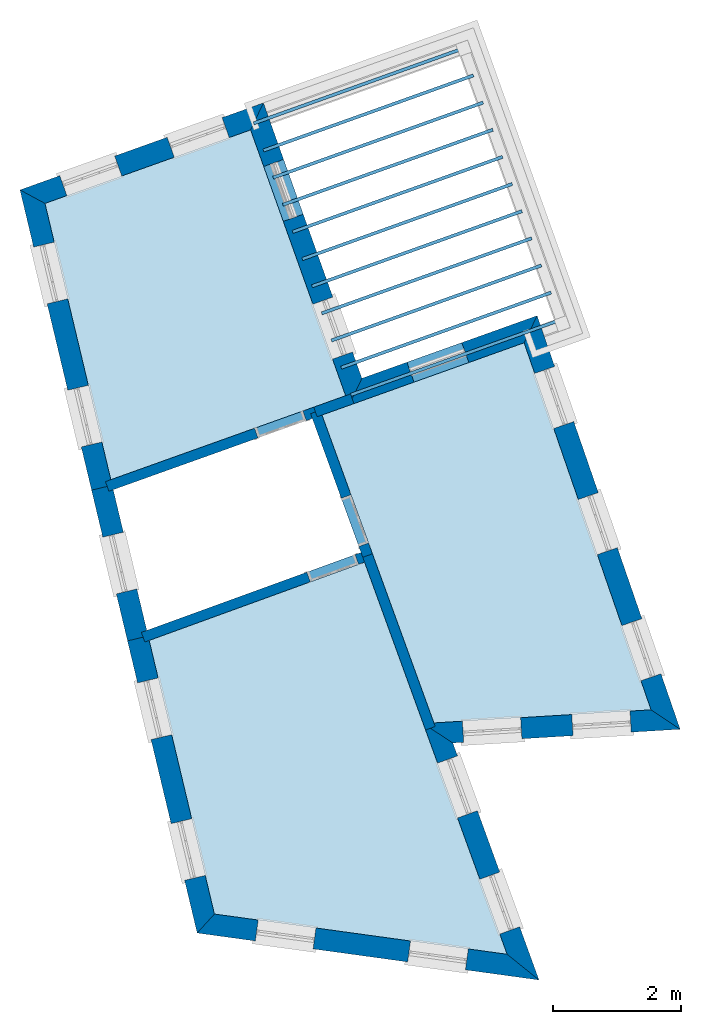
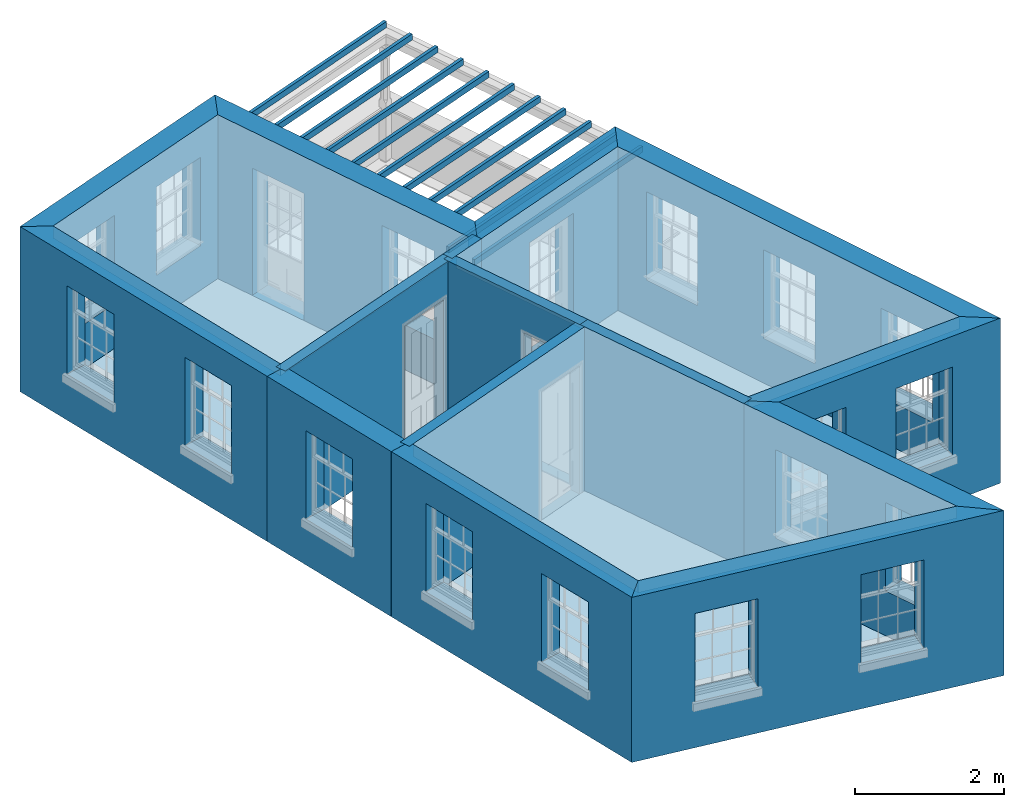
# One storey, part 1 of 12: 17 slabs, 15 walls, 22 openings.
"""IFC2X3 building model written with IfcOpenShell, lengths in metres."""

from ifc_helpers import new_model, si_unit, frame, origin, place, context, subcontext, project, spatial, polyline, outline, extrude, material, layer, layer_set, layer_usage, element, save


model = new_model("IFC2X3")

# Units and contexts
model_context = context("Model", 3, world=origin())
body_context = subcontext(model_context, "Body", "Model", "MODEL_VIEW")
ifc_project = project(units=[si_unit("PLANEANGLEUNIT", "RADIAN"), si_unit("MASSUNIT", "GRAM", prefix="KILO"), si_unit("FORCEUNIT", "NEWTON", prefix="KILO"), si_unit("LENGTHUNIT", "METRE")], contexts=[model_context])

# Site, building, storey
site_placement = place(None, origin())
site = spatial("IfcSite", under=ifc_project, at=site_placement, CompositionType="ELEMENT")
building_placement = place(None, origin())
building = spatial("IfcBuilding", under=site, at=building_placement, Name="Building plot-12", CompositionType="ELEMENT")
storey_placement = place(None, frame((0.0, 0.0, 6.45)))
storey = spatial("IfcBuildingStorey", under=building, at=storey_placement, Name="Floor 1", CompositionType="ELEMENT", Elevation=6.45)

# Slabs
slab_1_placement = place(storey_placement, frame((0.0, 0.0, 2.5)))
element("IfcSlab", 1, at=slab_1_placement, inside=storey, Name="Slab", ObjectType="Slab", PredefinedType="FLOOR", context=body_context, shape_type="SweptSolid", body=[
    extrude(outline(polyline([(56.3536968527592, 44.1243472572147), (53.1438565991735, 42.9766000900277), (54.1719070946365, 38.6653233374711), (57.8370699166001, 39.9758808462095), (56.3536968527592, 44.1243472572147)])), origin(), (0.0, 0.0, 1.0), 0.2),
])
slab_2_placement = place(storey_placement, frame((0.0, 0.0, 2.5)))
element("IfcSlab", 2, at=slab_2_placement, inside=storey, Name="Slab", ObjectType="Slab", PredefinedType="FLOOR", context=body_context, shape_type="SweptSolid", body=[
    extrude(outline(polyline([(57.4677288305129, 39.6738940222548), (59.2146610939911, 34.8688206458638), (62.6036094343713, 35.0733568984167), (60.6224114250311, 40.801918386454), (57.4677288305129, 39.6738940222548)])), origin(), (0.0, 0.0, 1.0), 0.2),
])
slab_3_placement = place(storey_placement, frame((0.0, 0.0, 2.5)))
element("IfcSlab", 3, at=slab_3_placement, inside=storey, Name="Slab", ObjectType="Slab", PredefinedType="FLOOR", context=body_context, shape_type="SweptSolid", body=[
    extrude(outline(polyline([(54.7702024726653, 36.1562861200959), (55.7885191142734, 31.8858296755126), (60.357257872223, 31.2577442307242), (58.1319962759778, 37.3784997260365), (54.7702024726653, 36.1562861200959)])), origin(), (0.0, 0.0, 1.0), 0.2),
])
slab_4_placement = place(storey_placement, frame((0.0, 0.0, 2.2)))
element("IfcSlab", 4, at=slab_4_placement, inside=storey, Name="Slab", ObjectType="Slab", PredefinedType="FLOOR", context=body_context, shape_type="SweptSolid", body=[
    extrude(outline(polyline([(56.3936730760147, 44.2501522713207), (56.4105077896063, 44.2030715701971), (59.6885342848072, 45.3752001892546), (59.6716995712156, 45.4222808903782), (56.3936730760147, 44.2501522713207)])), origin(), (0.0, 0.0, 1.0), 0.1),
])
slab_5_placement = place(storey_placement, frame((0.0, 0.0, 2.2)))
element("IfcSlab", 5, at=slab_5_placement, inside=storey, Name="Slab", ObjectType="Slab", PredefinedType="FLOOR", context=body_context, shape_type="SweptSolid", body=[
    extrude(outline(polyline([(56.5451854983388, 43.8264259612083), (56.5620202119304, 43.7793452600847), (59.8400467071313, 44.9514738791422), (59.8232119935397, 44.9985545802658), (56.5451854983388, 43.8264259612083)])), origin(), (0.0, 0.0, 1.0), 0.1),
])
slab_6_placement = place(storey_placement, frame((0.0, 0.0, 2.2)))
element("IfcSlab", 6, at=slab_6_placement, inside=storey, Name="Slab", ObjectType="Slab", PredefinedType="FLOOR", context=body_context, shape_type="SweptSolid", body=[
    extrude(outline(polyline([(56.6966979206629, 43.4026996510959), (56.7135326342544, 43.3556189499722), (59.9915591294554, 44.5277475690297), (59.9747244158638, 44.5748282701533), (56.6966979206629, 43.4026996510959)])), origin(), (0.0, 0.0, 1.0), 0.1),
])
slab_7_placement = place(storey_placement, frame((0.0, 0.0, 2.2)))
element("IfcSlab", 7, at=slab_7_placement, inside=storey, Name="Slab", ObjectType="Slab", PredefinedType="FLOOR", context=body_context, shape_type="SweptSolid", body=[
    extrude(outline(polyline([(56.848210342987, 42.9789733409834), (56.8650450565785, 42.9318926398598), (60.1430715517794, 44.1040212589173), (60.1262368381879, 44.1511019600409), (56.848210342987, 42.9789733409834)])), origin(), (0.0, 0.0, 1.0), 0.1),
])
slab_8_placement = place(storey_placement, frame((0.0, 0.0, 2.2)))
element("IfcSlab", 8, at=slab_8_placement, inside=storey, Name="Slab", ObjectType="Slab", PredefinedType="FLOOR", context=body_context, shape_type="SweptSolid", body=[
    extrude(outline(polyline([(56.999722765311, 42.555247030871), (57.0165574789026, 42.5081663297474), (60.2945839741035, 43.6802949488049), (60.277749260512, 43.7273756499285), (56.999722765311, 42.555247030871)])), origin(), (0.0, 0.0, 1.0), 0.1),
])
slab_9_placement = place(storey_placement, frame((0.0, 0.0, 2.2)))
element("IfcSlab", 9, at=slab_9_placement, inside=storey, Name="Slab", ObjectType="Slab", PredefinedType="FLOOR", context=body_context, shape_type="SweptSolid", body=[
    extrude(outline(polyline([(57.1512351876351, 42.1315207207586), (57.1680699012267, 42.084440019635), (60.4460963964276, 43.2565686386925), (60.4292616828361, 43.3036493398161), (57.1512351876351, 42.1315207207586)])), origin(), (0.0, 0.0, 1.0), 0.1),
])
slab_10_placement = place(storey_placement, frame((0.0, 0.0, 2.2)))
element("IfcSlab", 10, at=slab_10_placement, inside=storey, Name="Slab", ObjectType="Slab", PredefinedType="FLOOR", context=body_context, shape_type="SweptSolid", body=[
    extrude(outline(polyline([(57.3027476099592, 41.7077944106462), (57.3195823235507, 41.6607137095225), (60.5976088187517, 42.83284232858), (60.5807741051601, 42.8799230297036), (57.3027476099592, 41.7077944106462)])), origin(), (0.0, 0.0, 1.0), 0.1),
])
slab_11_placement = place(storey_placement, frame((0.0, 0.0, 2.2)))
element("IfcSlab", 11, at=slab_11_placement, inside=storey, Name="Slab", ObjectType="Slab", PredefinedType="FLOOR", context=body_context, shape_type="SweptSolid", body=[
    extrude(outline(polyline([(57.4542600322833, 41.2840681005337), (57.4710947458748, 41.2369873994101), (60.7491212410758, 42.4091160184676), (60.7322865274842, 42.4561967195912), (57.4542600322833, 41.2840681005337)])), origin(), (0.0, 0.0, 1.0), 0.1),
])
slab_12_placement = place(storey_placement, frame((0.0, 0.0, 2.2)))
element("IfcSlab", 12, at=slab_12_placement, inside=storey, Name="Slab", ObjectType="Slab", PredefinedType="FLOOR", context=body_context, shape_type="SweptSolid", body=[
    extrude(outline(polyline([(57.6057724546073, 40.8603417904213), (57.6226071681989, 40.8132610892977), (60.9006336633999, 41.9853897083552), (60.8837989498083, 42.0324704094788), (57.6057724546073, 40.8603417904213)])), origin(), (0.0, 0.0, 1.0), 0.1),
])
slab_13_placement = place(storey_placement, frame((0.0, 0.0, 2.2)))
element("IfcSlab", 13, at=slab_13_placement, inside=storey, Name="Slab", ObjectType="Slab", PredefinedType="FLOOR", context=body_context, shape_type="SweptSolid", body=[
    extrude(outline(polyline([(57.7572848769314, 40.4366154803089), (57.774119590523, 40.3895347791853), (61.052146085724, 41.5616633982428), (61.0353113721324, 41.6087440993664), (57.7572848769314, 40.4366154803089)])), origin(), (0.0, 0.0, 1.0), 0.1),
])
slab_14_placement = place(storey_placement, frame((0.0, 0.0, 2.2)))
element("IfcSlab", 14, at=slab_14_placement, inside=storey, Name="Slab", ObjectType="Slab", PredefinedType="FLOOR", context=body_context, shape_type="SweptSolid", body=[
    extrude(outline(polyline([(57.9087972992555, 40.0128891701965), (57.9256320128471, 39.9658084690729), (61.203658508048, 41.1379370881304), (61.1868237944565, 41.185017789254), (57.9087972992555, 40.0128891701965)])), origin(), (0.0, 0.0, 1.0), 0.1),
])
slab_15_placement = place(storey_placement, origin())
element("IfcSlab", 15, at=slab_15_placement, inside=storey, Name="Slab", ObjectType="Slab", PredefinedType="FLOOR", context=body_context, shape_type="SweptSolid", body=[
    extrude(outline(polyline([(56.3536968527592, 44.1243472572147), (53.1438565991735, 42.9766000900277), (54.1719070946365, 38.6653233374711), (57.8370699166001, 39.9758808462095), (56.3536968527592, 44.1243472572147)])), origin(), (0.0, 0.0, 1.0), 0.02),
])
slab_16_placement = place(storey_placement, origin())
element("IfcSlab", 16, at=slab_16_placement, inside=storey, Name="Slab", ObjectType="Slab", PredefinedType="FLOOR", context=body_context, shape_type="SweptSolid", body=[
    extrude(outline(polyline([(57.4677288305129, 39.6738940222548), (59.2146610939911, 34.8688206458638), (62.6036094343713, 35.0733568984167), (60.6224114250311, 40.801918386454), (57.4677288305129, 39.6738940222548)])), origin(), (0.0, 0.0, 1.0), 0.02),
])
slab_17_placement = place(storey_placement, origin())
element("IfcSlab", 17, at=slab_17_placement, inside=storey, Name="Slab", ObjectType="Slab", PredefinedType="FLOOR", context=body_context, shape_type="SweptSolid", body=[
    extrude(outline(polyline([(54.7702024726653, 36.1562861200959), (55.7885191142734, 31.8858296755126), (60.357257872223, 31.2577442307242), (58.1319962759778, 37.3784997260365), (54.7702024726653, 36.1562861200959)])), origin(), (0.0, 0.0, 1.0), 0.02),
])

# Wall, openings
ifc_material_1 = material(Name="Masonry")
ifc_layer_1 = layer(ifc_material_1, 0.33, ventilated=False)
ifc_layer_set_1 = layer_set([ifc_layer_1], Name="My Wall")
ifc_layer_usage_1 = layer_usage(ifc_layer_set_1, "AXIS2", "NEGATIVE", 0.08)
wall_1_placement = place(storey_placement, origin())
wall_1 = element("IfcWallStandardCase", 18, at=wall_1_placement, inside=storey, material=ifc_layer_usage_1, Name="exterior", context=body_context, shape_type="SweptSolid", body=[
    extrude(outline(polyline([(54.7536599454522, 36.2256595733621), (54.4326600181389, 36.1491151636064), (55.519891283054, 31.5896553921575), (55.7885191142734, 31.8858296755126), (54.7536599454522, 36.2256595733621)])), origin(), (0.0, 0.0, 1.0), 2.7),
])
opening_1_placement = place(storey_placement, frame((0.0, 0.0, 0.75)))
element("IfcOpeningElement", 19, at=opening_1_placement, cuts=wall_1, Name="Opening", ObjectType="Opening", context=body_context, shape_type="SweptSolid", body=[
    extrude(outline(polyline([(54.5890103724139, 35.4934375965852), (54.8000873811343, 34.6082559788424), (55.1210873084476, 34.6848003885981), (54.9100102997273, 35.5699820063409), (54.5890103724139, 35.4934375965852)])), origin(), (0.0, 0.0, 1.0), 1.445),
])
opening_2_placement = place(storey_placement, frame((0.0, 0.0, 0.75)))
element("IfcOpeningElement", 20, at=opening_2_placement, cuts=wall_1, Name="Opening", ObjectType="Opening", context=body_context, shape_type="SweptSolid", body=[
    extrude(outline(polyline([(55.1127880896844, 33.2969008447999), (55.3238650984048, 32.4117192270571), (55.6448650257181, 32.4882636368128), (55.4337880169978, 33.3734452545556), (55.1127880896844, 33.2969008447999)])), origin(), (0.0, 0.0, 1.0), 1.445),
])

wall_2_placement = place(storey_placement, origin())
wall_2 = element("IfcWallStandardCase", 21, at=wall_2_placement, inside=storey, material=ifc_layer_usage_1, Name="exterior", context=body_context, shape_type="SweptSolid", body=[
    extrude(outline(polyline([(55.7885191142734, 31.8858296755126), (55.519891283054, 31.5896553921575), (60.8543376208598, 30.856304618938), (60.357257872223, 31.2577442307242), (55.7885191142734, 31.8858296755126)])), origin(), (0.0, 0.0, 1.0), 2.7),
])
opening_3_placement = place(storey_placement, frame((0.0, 0.0, 0.75)))
element("IfcOpeningElement", 22, at=opening_3_placement, cuts=wall_2, Name="Opening", ObjectType="Opening", context=body_context, shape_type="SweptSolid", body=[
    extrude(outline(polyline([(56.4271796007389, 31.4649263111671), (57.3287004372119, 31.3409901122377), (57.3736443335269, 31.6679152507388), (56.472123497054, 31.7918514496683), (56.4271796007389, 31.4649263111671)])), origin(), (0.0, 0.0, 1.0), 1.445),
])
opening_4_placement = place(storey_placement, frame((0.0, 0.0, 0.75)))
element("IfcOpeningElement", 23, at=opening_4_placement, cuts=wall_2, Name="Opening", ObjectType="Opening", context=body_context, shape_type="SweptSolid", body=[
    extrude(outline(polyline([(58.8043620196962, 31.1381241550237), (59.7058828561692, 31.0141879560943), (59.7508267524843, 31.3411130945954), (58.8493059160113, 31.4650492935249), (58.8043620196962, 31.1381241550237)])), origin(), (0.0, 0.0, 1.0), 1.445),
])

wall_3_placement = place(storey_placement, origin())
wall_3 = element("IfcWallStandardCase", 24, at=wall_3_placement, inside=storey, material=ifc_layer_usage_1, Name="exterior", context=body_context, shape_type="SweptSolid", body=[
    extrude(outline(polyline([(60.357257872223, 31.2577442307242), (60.8543376208598, 30.856304618938), (59.5092760501621, 34.5560013261806), (59.0480704661197, 34.8587662516055), (60.357257872223, 31.2577442307242)])), origin(), (0.0, 0.0, 1.0), 2.7),
])
opening_5_placement = place(storey_placement, frame((0.0, 0.0, 0.75)))
element("IfcOpeningElement", 25, at=opening_5_placement, cuts=wall_3, Name="Opening", ObjectType="Opening", context=body_context, shape_type="SweptSolid", body=[
    extrude(outline(polyline([(60.5526263615271, 31.6861849582538), (60.241697889756, 32.541417958928), (59.9315584499511, 32.4286636779561), (60.2424869217222, 31.5734306772819), (60.5526263615271, 31.6861849582538)])), origin(), (0.0, 0.0, 1.0), 1.445),
])
opening_6_placement = place(storey_placement, frame((0.0, 0.0, 0.75)))
element("IfcOpeningElement", 26, at=opening_6_placement, cuts=wall_3, Name="Opening", ObjectType="Opening", context=body_context, shape_type="SweptSolid", body=[
    extrude(outline(polyline([(59.8936842748883, 33.4986565367382), (59.5827558031172, 34.3538895374124), (59.2726163633123, 34.2411352564405), (59.5835448350833, 33.3859022557663), (59.8936842748883, 33.4986565367382)])), origin(), (0.0, 0.0, 1.0), 1.445),
])

wall_4_placement = place(storey_placement, origin())
wall_4 = element("IfcWallStandardCase", 27, at=wall_4_placement, inside=storey, material=ifc_layer_usage_1, Name="exterior", context=body_context, shape_type="SweptSolid", body=[
    extrude(outline(polyline([(59.0480704661197, 34.8587662516055), (59.5092760501621, 34.5560013261806), (63.057647216937, 34.7701593682112), (62.6036094343713, 35.0733568984167), (59.0480704661197, 34.8587662516055)])), origin(), (0.0, 0.0, 1.0), 2.7),
])
opening_7_placement = place(storey_placement, frame((0.0, 0.0, 0.75)))
element("IfcOpeningElement", 28, at=opening_7_placement, cuts=wall_4, Name="Opening", ObjectType="Opening", context=body_context, shape_type="SweptSolid", body=[
    extrude(outline(polyline([(59.6792223070511, 34.5662582457403), (60.5875694412412, 34.6210805387303), (60.5676888294976, 34.9504811478322), (59.6593416953075, 34.8956588548422), (59.6792223070511, 34.5662582457403)])), origin(), (0.0, 0.0, 1.0), 1.445),
])
opening_8_placement = place(storey_placement, frame((0.0, 0.0, 0.75)))
element("IfcOpeningElement", 29, at=opening_8_placement, cuts=wall_4, Name="Opening", ObjectType="Opening", context=body_context, shape_type="SweptSolid", body=[
    extrude(outline(polyline([(61.3861163723973, 34.6692759611392), (62.2944635065874, 34.7240982541292), (62.2745828948438, 35.0534988632311), (61.3662357606537, 34.9986765702411), (61.3861163723973, 34.6692759611392)])), origin(), (0.0, 0.0, 1.0), 1.445),
])

wall_5_placement = place(storey_placement, origin())
wall_5 = element("IfcWallStandardCase", 30, at=wall_5_placement, inside=storey, material=ifc_layer_usage_1, Name="exterior", context=body_context, shape_type="SweptSolid", body=[
    extrude(outline(polyline([(62.6036094343713, 35.0733568984167), (63.057647216937, 34.7701593682112), (60.8252944529976, 41.2249256313146), (60.6224114250311, 40.801918386454), (62.6036094343713, 35.0733568984167)])), origin(), (0.0, 0.0, 1.0), 2.7),
])
opening_9_placement = place(storey_placement, frame((0.0, 0.0, 0.75)))
element("IfcOpeningElement", 31, at=opening_9_placement, cuts=wall_5, Name="Opening", ObjectType="Opening", context=body_context, shape_type="SweptSolid", body=[
    extrude(outline(polyline([(62.7583178339086, 35.6356593171161), (62.4608839337952, 36.4956785465891), (62.1490088286017, 36.387817901493), (62.4464427287151, 35.52779867202), (62.7583178339086, 35.6356593171161)])), origin(), (0.0, 0.0, 1.0), 1.445),
])
opening_10_placement = place(storey_placement, frame((0.0, 0.0, 0.75)))
element("IfcOpeningElement", 32, at=opening_10_placement, cuts=wall_5, Name="Opening", ObjectType="Opening", context=body_context, shape_type="SweptSolid", body=[
    extrude(outline(polyline([(62.0776231637569, 37.6038630272753), (61.7801892636435, 38.4638822567483), (61.46831415845, 38.3560216116522), (61.7657480585634, 37.4960023821792), (62.0776231637569, 37.6038630272753)])), origin(), (0.0, 0.0, 1.0), 1.445),
])
opening_11_placement = place(storey_placement, frame((0.0, 0.0, 0.75)))
element("IfcOpeningElement", 33, at=opening_11_placement, cuts=wall_5, Name="Opening", ObjectType="Opening", context=body_context, shape_type="SweptSolid", body=[
    extrude(outline(polyline([(61.3969284936051, 39.5720667374345), (61.0994945934918, 40.4320859669075), (60.7876194882983, 40.3242253218114), (61.0850533884116, 39.4642060923384), (61.3969284936051, 39.5720667374345)])), origin(), (0.0, 0.0, 1.0), 1.445),
])

# Wall, opening
wall_6_placement = place(storey_placement, origin())
wall_6 = element("IfcWallStandardCase", 34, at=wall_6_placement, inside=storey, material=ifc_layer_usage_1, Name="exterior", context=body_context, shape_type="SweptSolid", body=[
    extrude(outline(polyline([(60.6224114250311, 40.801918386454), (60.8252944529976, 41.2249256313146), (58.0905645178046, 40.247064339734), (57.8909410000931, 39.8252226026139), (60.6224114250311, 40.801918386454)])), origin(), (0.0, 0.0, 1.0), 2.7),
])
opening_12_placement = place(storey_placement, frame((0.0, 0.0, 0.0199999999999996)))
element("IfcOpeningElement", 35, at=opening_12_placement, cuts=wall_6, Name="Opening", ObjectType="Opening", context=body_context, shape_type="SweptSolid", body=[
    extrude(outline(polyline([(59.6497256970325, 40.804575831045), (58.7928569365829, 40.4981840436785), (58.9039660462872, 40.1874514162628), (59.7608348067368, 40.4938432036292), (59.6497256970325, 40.804575831045)])), origin(), (0.0, 0.0, 1.0), 2.08),
])

# Wall, openings
wall_7_placement = place(storey_placement, origin())
wall_7 = element("IfcWallStandardCase", 36, at=wall_7_placement, inside=storey, material=ifc_layer_usage_1, Name="exterior", context=body_context, shape_type="SweptSolid", body=[
    extrude(outline(polyline([(57.8909410000931, 39.8252226026139), (58.0905645178046, 40.247064339734), (56.5533203704707, 44.5461889943348), (56.3536968527592, 44.1243472572147), (57.8909410000931, 39.8252226026139)])), origin(), (0.0, 0.0, 1.0), 2.7),
])
opening_13_placement = place(storey_placement, frame((0.0, 0.0, 0.75)))
element("IfcOpeningElement", 37, at=opening_13_placement, cuts=wall_7, Name="Opening", ObjectType="Opening", context=body_context, shape_type="SweptSolid", body=[
    extrude(outline(polyline([(57.9436229426122, 40.6580076175414), (57.6372311552457, 41.514876377991), (57.3264985278299, 41.4037672682867), (57.6328903151964, 40.5468985078371), (57.9436229426122, 40.6580076175414)])), origin(), (0.0, 0.0, 1.0), 1.445),
])
opening_14_placement = place(storey_placement, frame((0.0, 0.0, 0.0199999999999996)))
element("IfcOpeningElement", 38, at=opening_14_placement, cuts=wall_7, Name="Opening", ObjectType="Opening", context=body_context, shape_type="SweptSolid", body=[
    extrude(outline(polyline([(57.1750008689452, 42.8075699448418), (56.8686090815788, 43.6644387052913), (56.557876454163, 43.553329595587), (56.8642682415294, 42.6964608351374), (57.1750008689452, 42.8075699448418)])), origin(), (0.0, 0.0, 1.0), 2.08),
])

wall_8_placement = place(storey_placement, origin())
wall_8 = element("IfcWallStandardCase", 39, at=wall_8_placement, inside=storey, material=ifc_layer_usage_1, Name="exterior", context=body_context, shape_type="SweptSolid", body=[
    extrude(outline(polyline([(56.3536968527592, 44.1243472572147), (56.5533203704707, 44.5461889943348), (52.7542538663581, 43.1877513545865), (53.1438565991735, 42.9766000900277), (56.3536968527592, 44.1243472572147)])), origin(), (0.0, 0.0, 1.0), 2.7),
])
opening_15_placement = place(storey_placement, frame((0.0, 0.0, 0.75)))
element("IfcOpeningElement", 40, at=opening_15_placement, cuts=wall_8, Name="Opening", ObjectType="Opening", context=body_context, shape_type="SweptSolid", body=[
    extrude(outline(polyline([(55.9081804998309, 44.3155054087142), (55.0513117393813, 44.0091136213478), (55.1624208490857, 43.698380993932), (56.0192896095352, 44.0047727812985), (55.9081804998309, 44.3155054087142)])), origin(), (0.0, 0.0, 1.0), 1.445),
])
opening_16_placement = place(storey_placement, frame((0.0, 0.0, 0.75)))
element("IfcOpeningElement", 41, at=opening_16_placement, cuts=wall_8, Name="Opening", ObjectType="Opening", context=body_context, shape_type="SweptSolid", body=[
    extrude(outline(polyline([(54.2318390093378, 43.7160935860224), (53.3749702488882, 43.409701798656), (53.4860793585926, 43.0989691712402), (54.3429481190421, 43.4053609586067), (54.2318390093378, 43.7160935860224)])), origin(), (0.0, 0.0, 1.0), 1.445),
])

wall_9_placement = place(storey_placement, origin())
wall_9 = element("IfcWallStandardCase", 42, at=wall_9_placement, inside=storey, material=ifc_layer_usage_1, Name="exterior", context=body_context, shape_type="SweptSolid", body=[
    extrude(outline(polyline([(53.1438565991735, 42.9766000900277), (52.7542538663581, 43.1877513545865), (53.8716114947725, 38.5019523700673), (54.1926114220858, 38.578496779823), (53.1438565991735, 42.9766000900277)])), origin(), (0.0, 0.0, 1.0), 2.7),
])
opening_17_placement = place(storey_placement, frame((0.0, 0.0, 0.75)))
element("IfcOpeningElement", 43, at=opening_17_placement, cuts=wall_9, Name="Opening", ObjectType="Opening", context=body_context, shape_type="SweptSolid", body=[
    extrude(outline(polyline([(52.9670336358641, 42.295428966013), (53.1781106445844, 41.4102473482703), (53.4991105718977, 41.486791758026), (53.2880335631774, 42.3719733757687), (52.9670336358641, 42.295428966013)])), origin(), (0.0, 0.0, 1.0), 1.445),
])
opening_18_placement = place(storey_placement, frame((0.0, 0.0, 0.75)))
element("IfcOpeningElement", 44, at=opening_18_placement, cuts=wall_9, Name="Opening", ObjectType="Opening", context=body_context, shape_type="SweptSolid", body=[
    extrude(outline(polyline([(53.4997265388962, 40.0615051079635), (53.7108035476165, 39.1763234902207), (54.0318034749299, 39.2528678999764), (53.8207264662095, 40.1380495177192), (53.4997265388962, 40.0615051079635)])), origin(), (0.0, 0.0, 1.0), 1.445),
])

# Wall, opening
wall_10_placement = place(storey_placement, origin())
wall_10 = element("IfcWallStandardCase", 45, at=wall_10_placement, inside=storey, material=ifc_layer_usage_1, Name="exterior", context=body_context, shape_type="SweptSolid", body=[
    extrude(outline(polyline([(54.1926114220858, 38.578496779823), (53.8716114947725, 38.5019523700673), (54.4326600181389, 36.1491151636064), (54.7536599454522, 36.2256595733621), (54.1926114220858, 38.578496779823)])), origin(), (0.0, 0.0, 1.0), 2.7),
])
opening_19_placement = place(storey_placement, frame((0.0, 0.0, 0.75)))
element("IfcOpeningElement", 46, at=opening_19_placement, cuts=wall_10, Name="Opening", ObjectType="Opening", context=body_context, shape_type="SweptSolid", body=[
    extrude(outline(polyline([(54.0465972520955, 37.7681245757082), (54.2576742608158, 36.8829429579655), (54.5786741881291, 36.9594873677212), (54.3675971794088, 37.844668985464), (54.0465972520955, 37.7681245757082)])), origin(), (0.0, 0.0, 1.0), 1.445),
])

# Wall
ifc_material_2 = material(Name="Masonry")
ifc_layer_2 = layer(ifc_material_2, 0.16, ventilated=False)
ifc_layer_set_2 = layer_set([ifc_layer_2], Name="My Wall")
ifc_layer_usage_2 = layer_usage(ifc_layer_set_2, "AXIS2", "NEGATIVE", 0.08)
wall_11_placement = place(storey_placement, origin())
element("IfcWallStandardCase", 47, at=wall_11_placement, inside=storey, material=ifc_layer_usage_2, Name="interior", context=body_context, shape_type="SweptSolid", body=[
    extrude(outline(polyline([(57.3381283541499, 39.7974735986045), (57.3919994376429, 39.6468153550089), (57.9662701218909, 39.8521581443604), (57.9123990383979, 40.002816387956), (57.3381283541499, 39.7974735986045)])), origin(), (0.0, 0.0, 1.0), 2.7),
])

# Wall, opening
wall_12_placement = place(storey_placement, origin())
wall_12 = element("IfcWallStandardCase", 48, at=wall_12_placement, inside=storey, material=ifc_layer_usage_2, Name="interior", context=body_context, shape_type="SweptSolid", body=[
    extrude(outline(polyline([(57.3919994376429, 39.6468153550089), (57.3381283541499, 39.7974735986045), (54.0878577161421, 38.635269681074), (54.1417287996351, 38.4846114374784), (57.3919994376429, 39.6468153550089)])), origin(), (0.0, 0.0, 1.0), 2.7),
])
opening_20_placement = place(storey_placement, frame((0.0, 0.0, 0.0199999999999996)))
element("IfcOpeningElement", 49, at=opening_20_placement, cuts=wall_12, Name="Opening", ObjectType="Opening", context=body_context, shape_type="SweptSolid", body=[
    extrude(outline(polyline([(57.1686378301049, 39.7368686296748), (56.4153466121273, 39.4675132122098), (56.4692176956203, 39.3168549686143), (57.2225089135979, 39.5862103860793), (57.1686378301049, 39.7368686296748)])), origin(), (0.0, 0.0, 1.0), 2.1),
])

wall_13_placement = place(storey_placement, origin())
wall_13 = element("IfcWallStandardCase", 50, at=wall_13_placement, inside=storey, material=ifc_layer_usage_2, Name="interior", context=body_context, shape_type="SweptSolid", body=[
    extrude(outline(polyline([(57.440249214637, 39.7494788479514), (57.2898785771558, 39.694810105662), (58.1046619048331, 37.4536850447771), (58.2550325423143, 37.5083537870665), (57.440249214637, 39.7494788479514)])), origin(), (0.0, 0.0, 1.0), 2.7),
])
opening_21_placement = place(storey_placement, frame((0.0, 0.0, 0.0199999999999996)))
element("IfcOpeningElement", 51, at=opening_21_placement, cuts=wall_13, Name="Opening", ObjectType="Opening", context=body_context, shape_type="SweptSolid", body=[
    extrude(outline(polyline([(57.7698158583105, 38.3747051993493), (58.0431595697575, 37.6228520119434), (58.1935302072387, 37.6775207542328), (57.9201864957916, 38.4293739416387), (57.7698158583105, 38.3747051993493)])), origin(), (0.0, 0.0, 1.0), 2.1),
])

wall_14_placement = place(storey_placement, origin())
wall_14 = element("IfcWallStandardCase", 52, at=wall_14_placement, inside=storey, material=ifc_layer_usage_2, Name="interior", context=body_context, shape_type="SweptSolid", body=[
    extrude(outline(polyline([(58.2071815947184, 37.4058340971812), (58.152512852429, 37.5562047346624), (54.6485074101103, 36.2822886715559), (54.7031761523997, 36.1319180340747), (58.2071815947184, 37.4058340971812)])), origin(), (0.0, 0.0, 1.0), 2.7),
])
opening_22_placement = place(storey_placement, frame((0.0, 0.0, 0.0199999999999996)))
element("IfcOpeningElement", 53, at=opening_22_placement, cuts=wall_14, Name="Opening", ObjectType="Opening", context=body_context, shape_type="SweptSolid", body=[
    extrude(outline(polyline([(57.9833458852627, 37.4947023995868), (57.2314926978568, 37.2213586881397), (57.2861614401462, 37.0709880506585), (58.0380146275521, 37.3443317621056), (57.9833458852627, 37.4947023995868)])), origin(), (0.0, 0.0, 1.0), 2.1),
])

# Wall
wall_15_placement = place(storey_placement, origin())
element("IfcWallStandardCase", 54, at=wall_15_placement, inside=storey, material=ifc_layer_usage_2, Name="interior", context=body_context, shape_type="SweptSolid", body=[
    extrude(outline(polyline([(58.2550325423143, 37.5083537870665), (58.1046619048331, 37.4536850447771), (59.0846925616924, 34.758034322782), (59.2350631991736, 34.8127030650714), (58.2550325423143, 37.5083537870665)])), origin(), (0.0, 0.0, 1.0), 2.7),
])

save(model, "model.ifc")
